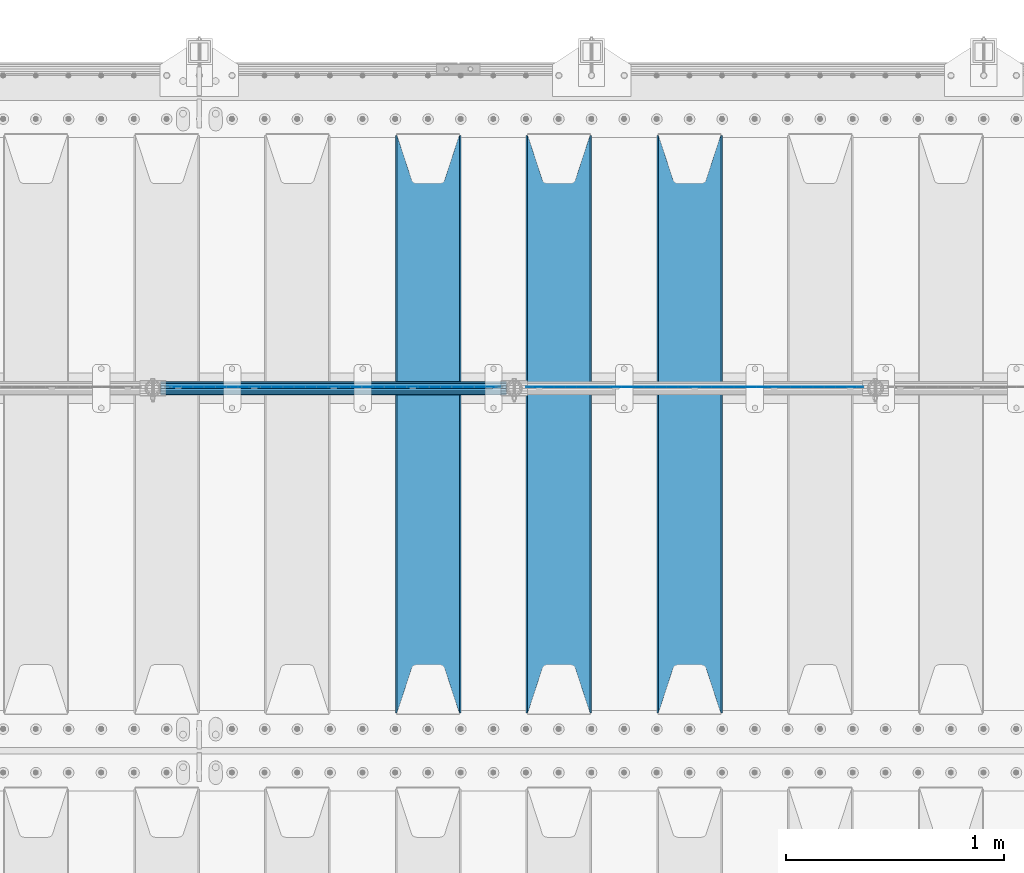
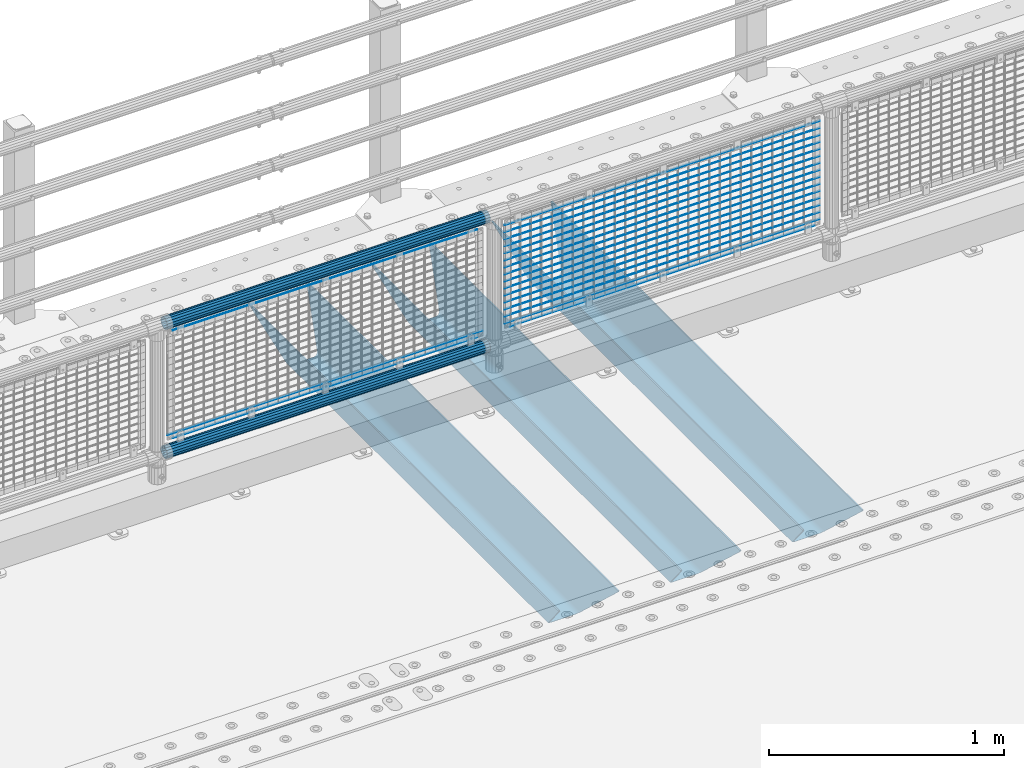
# One storey, part 91 of 193: 24 beams.
"""IFC2X3 building model written with IfcOpenShell, lengths in millimetres."""

import ifcopenshell
import ifcopenshell.guid

model = None  # the IFC model being written
_history = None  # IfcOwnerHistory: only IFC2X3 demands one
_inside = {}  # id of a spatial element -> (the spatial element, [elements in it])
_under = {}  # id of a project, library or spatial element -> (it, [spatial elements below it])
_declared = {}  # id of a project -> (the project, [libraries it declares])
_typed = {}  # id of a type object -> (the type object, [elements of that type])
_made_of = {}  # id of a material, layer set ... -> (it, [elements and type objects made of it])


def new_model(schema):
    """Start an empty IFC model of exactly this schema.

    Asked for "IFC4X3", IfcOpenShell would pick the latest addendum, in which some entities
    have other attributes; the version numbers below select the first issue.
    IFC2X3 requires an IfcOwnerHistory on every rooted entity: one is made here for all.
    """
    global model, _history
    if schema == "IFC4X3":
        model = ifcopenshell.file(schema_version=(4, 3, 0, 0))
    else:
        model = ifcopenshell.file(schema=schema)
    _inside.clear()
    _under.clear()
    _declared.clear()
    _typed.clear()
    _made_of.clear()
    _history = None
    if model.schema == "IFC2X3":
        org = make("IfcOrganization", Name="unknown")
        user = make(
            "IfcPersonAndOrganization",
            ThePerson=make("IfcPerson", FamilyName="unknown"),
            TheOrganization=org,
        )
        app = make(
            "IfcApplication",
            ApplicationDeveloper=org,
            Version="unknown",
            ApplicationFullName="unknown",
            ApplicationIdentifier="unknown",
        )
        _history = make(
            "IfcOwnerHistory",
            OwningUser=user,
            OwningApplication=app,
            ChangeAction="ADDED",
            CreationDate=0,
        )
    return model


def make(cls, **values):
    """One entity of the class cls with the attributes given. An attribute that is None is left unset."""
    return model.create_entity(
        cls, **{name: value for name, value in values.items() if value is not None}
    )


def rooted(cls, **values):
    """An entity with a GlobalId (a new one), such as an element, a storey or a relation."""
    return make(cls, GlobalId=ifcopenshell.guid.new(), OwnerHistory=_history, **values)


def si_unit(unit_type, name, prefix=None):
    """IfcSIUnit, for example si_unit("LENGTHUNIT", "METRE", prefix="MILLI")."""
    return make("IfcSIUnit", UnitType=unit_type, Prefix=prefix, Name=name)


def assignment(units):
    """IfcUnitAssignment: the units of a project."""
    return None if units is None else make("IfcUnitAssignment", Units=units)


def point(xyz):
    """IfcCartesianPoint."""
    return None if xyz is None else make("IfcCartesianPoint", Coordinates=xyz)


def direction(xyz):
    """IfcDirection."""
    return None if xyz is None else make("IfcDirection", DirectionRatios=xyz)


def frame(location, z_axis=None, x_axis=None):
    """IfcAxis2Placement3D, a coordinate frame: its origin and axes. An axis left out is left unset."""
    return make(
        "IfcAxis2Placement3D",
        Location=point(location),
        Axis=direction(z_axis),
        RefDirection=direction(x_axis),
    )


def origin_with_axes():
    """The frame at (0, 0, 0) with the z axis (0, 0, 1) and the x axis (1, 0, 0) written out."""
    return frame((0.0, 0.0, 0.0), z_axis=(0.0, 0.0, 1.0), x_axis=(1.0, 0.0, 0.0))


def place(relative_to, where):
    """IfcLocalPlacement: puts the frame where relative to a parent placement (None: the world)."""
    return make(
        "IfcLocalPlacement", PlacementRelTo=relative_to, RelativePlacement=where
    )


def context(
    kind, dimensions, precision=None, world=None, true_north=None, identifier=None
):
    """IfcGeometricRepresentationContext, for example the 3D "Model" context."""
    return make(
        "IfcGeometricRepresentationContext",
        ContextIdentifier=identifier,
        ContextType=kind,
        CoordinateSpaceDimension=dimensions,
        Precision=precision,
        WorldCoordinateSystem=world,
        TrueNorth=true_north,
    )


def subcontext(parent, identifier, kind, view, scale=None):
    """IfcGeometricRepresentationSubContext, for example "Body" below "Model"."""
    return make(
        "IfcGeometricRepresentationSubContext",
        ContextIdentifier=identifier,
        ContextType=kind,
        ParentContext=parent,
        TargetScale=scale,
        TargetView=view,
    )


def project(units=None, contexts=None):
    """IfcProject with its units and contexts."""
    return rooted(
        "IfcProject",
        Name="project",
        RepresentationContexts=contexts,
        UnitsInContext=assignment(units),
    )


def spatial(cls, under=None, at=None, **own):
    """A site, building, storey or space (cls), placed at a placement, below another one or the project."""
    s = rooted(cls, ObjectPlacement=at, **own)
    if under is not None:
        _under.setdefault(under.id(), (under, []))[1].append(s)
    return s


def faces_of(points, faces, orient=None, outer=None):
    """IfcFace entities. A face is a list of loops; a loop is a list of indices into points, from 0.

    orient and outer hold one flag for each loop. By default every Orientation is true, the
    first loop of a face is its IfcFaceOuterBound and the others are IfcFaceBound.
    """
    made = []
    for i, loops in enumerate(faces):
        bounds = []
        for j, loop in enumerate(loops):
            is_outer = j == 0 if outer is None else outer[i][j]
            bounds.append(
                make(
                    "IfcFaceOuterBound" if is_outer else "IfcFaceBound",
                    Bound=make("IfcPolyLoop", Polygon=[points[k] for k in loop]),
                    Orientation=True if orient is None else orient[i][j],
                )
            )
        made.append(make("IfcFace", Bounds=bounds))
    return made


def faceted_brep(points, faces, orient=None, outer=None, voids=None):
    """IfcFacetedBrep: a solid bounded by flat faces; with voids (closed shells), ...WithVoids."""
    shared = [point(p) for p in points]
    hull = make("IfcClosedShell", CfsFaces=faces_of(shared, faces, orient, outer))
    if voids is None:
        return make("IfcFacetedBrep", Outer=hull)
    return make(
        "IfcFacetedBrepWithVoids",
        Outer=hull,
        Voids=[
            make(cls, CfsFaces=faces_of(shared, fs, o, b)) for cls, fs, o, b in voids
        ],
    )


def shape(context_of_items, identifier, shape_type, items):
    """IfcShapeRepresentation: the items that make up one representation, for example the "Body"."""
    return make(
        "IfcShapeRepresentation",
        ContextOfItems=context_of_items,
        RepresentationIdentifier=identifier,
        RepresentationType=shape_type,
        Items=items,
    )


def material(Name=None, Category=None):
    """IfcMaterial."""
    return make("IfcMaterial", Name=Name, Category=Category)


def made_of(thing, what):
    """Note that an element or type object is made of a material, layer set ...; save() writes the relation."""
    if what is not None:
        _made_of.setdefault(what.id(), (what, []))[1].append(thing)
    return thing


def type_object(cls, material=None, **own):
    """A type object (cls), such as IfcWallType, which elements share."""
    return made_of(rooted(cls, **own), material)


def element(
    cls,
    number,
    at=None,
    inside=None,
    cuts=None,
    type_object=None,
    material=None,
    context=None,
    identifier="Body",
    shape_type=None,
    held_by="IfcProductDefinitionShape",
    body=None,
    shapes=None,
    **own,
):
    """One element of the class cls, such as IfcWall. Its Tag is "e" and its number.

    at: its placement. inside: the storey or other place that contains it. cuts: it is an
    opening in that element (IfcRelVoidsElement). A single representation is given by context,
    identifier, shape_type and body (its items); several are given by shapes. held_by: the class
    of the entity that holds the representations. save() writes the other relations.
    """
    e = rooted(cls, Tag="e%d" % number, ObjectPlacement=at, **own)
    if body is not None:
        shapes = [shape(context, identifier, shape_type, body)]
    if shapes is not None:
        e.Representation = make(held_by, Representations=shapes)
    if inside is not None:
        _inside.setdefault(inside.id(), (inside, []))[1].append(e)
    if cuts is not None:
        rooted(
            "IfcRelVoidsElement", RelatingBuildingElement=cuts, RelatedOpeningElement=e
        )
    if type_object is not None:
        _typed.setdefault(type_object.id(), (type_object, []))[1].append(e)
    return made_of(e, material)


def aggregate(whole, parts):
    """IfcRelAggregates: a whole, such as a stair, and the parts it consists of."""
    return rooted("IfcRelAggregates", RelatingObject=whole, RelatedObjects=parts)


def save(model, path):
    """Write the relations noted so far, then the file.

    IfcRelAggregates (storeys below a building ...), IfcRelContainedInSpatialStructure (elements
    in a storey), IfcRelDefinesByType, IfcRelAssociatesMaterial and IfcRelDeclares: one each for
    every whole, place, type object, material and project.
    """
    for whole, parts in _under.values():
        aggregate(whole, parts)
    for where, things in _inside.values():
        rooted(
            "IfcRelContainedInSpatialStructure",
            RelatedElements=things,
            RelatingStructure=where,
        )
    for kind, things in _typed.values():
        rooted("IfcRelDefinesByType", RelatedObjects=things, RelatingType=kind)
    for what, things in _made_of.values():
        rooted("IfcRelAssociatesMaterial", RelatedObjects=things, RelatingMaterial=what)
    for by, libraries in _declared.values():
        rooted("IfcRelDeclares", RelatingContext=by, RelatedDefinitions=libraries)
    model.write(path)


model = new_model("IFC2X3")

# Units and contexts
model_context = context("Model", 3, precision=1e-05, world=origin_with_axes())
body_context = subcontext(model_context, "Body", "Model", "MODEL_VIEW")
ifc_project = project(units=[si_unit("LENGTHUNIT", "METRE", prefix="MILLI"), si_unit("AREAUNIT", "SQUARE_METRE"), si_unit("VOLUMEUNIT", "CUBIC_METRE"), si_unit("MASSUNIT", "GRAM", prefix="KILO"), si_unit("TIMEUNIT", "SECOND"), si_unit("PLANEANGLEUNIT", "RADIAN"), si_unit("SOLIDANGLEUNIT", "STERADIAN"), si_unit("THERMODYNAMICTEMPERATUREUNIT", "DEGREE_CELSIUS"), si_unit("LUMINOUSINTENSITYUNIT", "LUMEN")], contexts=[model_context])

# Site, building, storey
site_placement = place(None, origin_with_axes())
site = spatial("IfcSite", under=ifc_project, at=site_placement, CompositionType="ELEMENT")
building_placement = place(site_placement, origin_with_axes())
building = spatial("IfcBuilding", under=site, at=building_placement, Name="Standard", CompositionType="ELEMENT")
storey_placement = place(building_placement, origin_with_axes())
storey = spatial("IfcBuildingStorey", under=building, at=storey_placement, Name="Undefined", CompositionType="ELEMENT", Elevation=0.0)

# Beams
ifc_material_1 = material(Name="STEEL/S355N")
beam_type_1 = type_object("IfcBeamType", PredefinedType="NOTDEFINED")
beam_1_placement = place(storey_placement, frame((-36050.0, 27175.0, -115.0), z_axis=(0.0, 0.0, 1.0), x_axis=(0.0, 1.0, 0.0)))
element("IfcBeam", 1, at=beam_1_placement, inside=storey, type_object=beam_type_1, material=ifc_material_1, context=body_context, shape_type="Brep", body=[
    faceted_brep([(0.0, 150.0, 115.0), (0.0, 143.689999999999, 115.0), (2650.00000000297, 143.689999999999, 115.0), (2650.00000000297, 150.0, 115.0), (2650.00000000297, 142.059565218398, 110.000000003094), (2650.00000000297, 148.3695652184, 110.000000003094), (2441.90079219209, -80.1103600731112, -98.0992078077845), (2437.7588105432, -77.5672621345584, -102.241189456673), (2434.06523489747, -74.4080125315522, -105.934765102404), (2430.9108609509, -70.710272125576, -109.089139048974), (2428.37322971128, -66.5649389910068, -111.626770288588), (2426.51472138055, -62.0739139532889, -113.485278619323), (2425.38102192092, -57.3475956567672, -114.618978078955), (2424.99999999988, -52.5021667386536, -115.0), (2424.99999999988, 52.5021667386536, -115.0), (2425.38102192092, 57.3475956567672, -114.618978078955), (2426.51472138055, 62.0739139532889, -113.485278619323), (2428.37322971128, 66.5649389910068, -111.626770288588), (2430.9108609509, 70.710272125576, -109.089139048974), (2434.06523489747, 74.4080125315522, -105.934765102404), (2437.7588105432, 77.5672621345584, -102.241189456673), (2441.90079219209, 80.1103600731112, -98.0992078077846), (2446.38936140512, 81.9747917625791, -93.6106385947584), (2448.2494850041, 76.2713538057251, -91.7505149957729), (2444.62967112263, 74.76777986261, -95.3703288772456), (2441.28936334127, 72.7168944282894, -98.710636658607), (2438.31067330439, 70.1691124903846, -101.689326695487), (2435.76682334748, 67.1870637758839, -104.233176652398), (2433.72034654134, 63.8440531834895, -106.279653458539), (2432.22154950042, 60.222258798236, -107.778450499454), (2431.30727574265, 56.4107117849089, -108.692724257221), (2430.99999999987, 52.5031078186876, -109.0), (2430.99999999987, -52.5031078186876, -109.0), (2431.30727574265, -56.4107117849089, -108.692724257221), (2432.22154950042, -60.222258798236, -107.778450499454), (2433.72034654134, -63.8440531834895, -106.279653458539), (2435.76682334748, -67.1870637758839, -104.233176652398), (2438.31067330439, -70.1691124903846, -101.689326695487), (2441.28936334127, -72.7168944282894, -98.7106366586071), (2444.62967112263, -74.76777986261, -95.3703288772457), (2448.2494850041, -76.2713538057251, -91.7505149957729), (2650.00000000297, -142.059565218398, 110.000000003094), (2650.00000000297, -148.3695652184, 110.000000003094), (2446.38936140512, -81.9747917625791, -93.6106385947584), (2650.00000000297, -143.689999999999, 115.0), (2650.00000000297, -150.0, 115.0), (0.0, -143.689999999999, 115.0), (0.0, -150.0, 115.0), (0.0, -148.369565218261, 110.000000002667), (203.610638597427, -81.9747917625791, -93.6106385947584), (208.099207810446, -80.1103600731112, -98.0992078077845), (212.241189459342, -77.5672621345584, -102.241189456673), (215.93476510507, -74.4080125315522, -105.934765102404), (219.089139051641, -70.710272125576, -109.089139048974), (221.626770291256, -66.5649389910068, -111.626770288588), (223.485278621989, -62.0739139532889, -113.485278619323), (224.618978081624, -57.3475956567672, -114.618978078955), (225.000000002663, -52.5021667386536, -115.0), (225.000000002663, 52.5021667386536, -115.0), (224.618978081624, 57.3475956567672, -114.618978078955), (223.485278621989, 62.0739139532889, -113.485278619323), (221.626770291256, 66.5649389910068, -111.626770288588), (219.089139051641, 70.710272125576, -109.089139048974), (215.93476510507, 74.4080125315522, -105.934765102404), (212.241189459342, 77.5672621345584, -102.241189456673), (208.099207810446, 80.1103600731112, -98.0992078077846), (203.610638597427, 81.9747917625791, -93.6106385947584), (0.0, 148.369565218261, 110.000000002667), (0.0, 142.05956521826, 110.000000002667), (201.750514998439, 76.2713538057251, -91.7505149957729), (205.370328879915, 74.76777986261, -95.3703288772456), (208.710636661275, 72.7168944282894, -98.710636658607), (211.689326698157, 70.1691124903846, -101.689326695487), (214.233176655063, 67.1870637758839, -104.233176652398), (216.279653461206, 63.8440531834895, -106.279653458539), (217.778450502123, 60.222258798236, -107.778450499454), (218.69272425989, 56.4107117849089, -108.692724257221), (219.00000000267, 52.5031078186876, -109.0), (219.00000000267, -52.5031078186876, -109.0), (218.69272425989, -56.4107117849089, -108.692724257221), (217.778450502123, -60.222258798236, -107.778450499454), (216.279653461206, -63.8440531834895, -106.279653458539), (214.233176655063, -67.1870637758839, -104.233176652398), (211.689326698157, -70.1691124903846, -101.689326695487), (208.710636661275, -72.7168944282894, -98.7106366586071), (205.370328879915, -74.76777986261, -95.3703288772457), (201.750514998439, -76.2713538057251, -91.7505149957729), (0.0, -142.05956521826, 110.000000002667)], [[[0, 1, 2, 3]], [[3, 2, 4, 5]], [[6, 7, 8, 9, 10, 11, 12, 13, 14, 15, 16, 17, 18, 19, 20, 21, 22, 5, 4, 23, 24, 25, 26, 27, 28, 29, 30, 31, 32, 33, 34, 35, 36, 37, 38, 39, 40, 41, 42, 43]], [[44, 45, 42, 41]], [[46, 47, 45, 44]], [[43, 42, 45, 47, 48, 49]], [[6, 43, 49, 50]], [[7, 6, 50, 51]], [[8, 7, 51, 52]], [[9, 8, 52, 53]], [[10, 9, 53, 54]], [[11, 10, 54, 55]], [[12, 11, 55, 56]], [[13, 12, 56, 57]], [[14, 13, 57, 58]], [[15, 14, 58, 59]], [[16, 15, 59, 60]], [[17, 16, 60, 61]], [[18, 17, 61, 62]], [[19, 18, 62, 63]], [[20, 19, 63, 64]], [[21, 20, 64, 65]], [[22, 21, 65, 66]], [[0, 3, 5, 22, 66, 67]], [[1, 0, 67, 68]], [[23, 4, 2, 1, 68, 69]], [[24, 23, 69, 70]], [[25, 24, 70, 71]], [[26, 25, 71, 72]], [[27, 26, 72, 73]], [[28, 27, 73, 74]], [[29, 28, 74, 75]], [[30, 29, 75, 76]], [[31, 30, 76, 77]], [[32, 31, 77, 78]], [[33, 32, 78, 79]], [[34, 33, 79, 80]], [[35, 34, 80, 81]], [[36, 35, 81, 82]], [[37, 36, 82, 83]], [[38, 37, 83, 84]], [[39, 38, 84, 85]], [[40, 39, 85, 86]], [[46, 44, 41, 40, 86, 87]], [[47, 46, 87, 48]], [[86, 85, 84, 83, 82, 81, 80, 79, 78, 77, 76, 75, 74, 73, 72, 71, 70, 69, 68, 67, 66, 65, 64, 63, 62, 61, 60, 59, 58, 57, 56, 55, 54, 53, 52, 51, 50, 49, 48, 87]]]),
])
beam_2_placement = place(storey_placement, frame((-36650.0, 27175.0, -115.0), z_axis=(0.0, 0.0, 1.0), x_axis=(0.0, 1.0, 0.0)))
element("IfcBeam", 2, at=beam_2_placement, inside=storey, type_object=beam_type_1, material=ifc_material_1, context=body_context, shape_type="Brep", body=[
    faceted_brep([(0.0, 150.0, 115.0), (0.0, 143.689999999999, 115.0), (2650.00000000297, 143.689999999999, 115.0), (2650.00000000297, 150.0, 115.0), (2650.00000000297, 142.059565218398, 110.000000003094), (2650.00000000297, 148.3695652184, 110.000000003094), (2441.90079219209, -80.1103600731112, -98.0992078077845), (2437.7588105432, -77.5672621345584, -102.241189456673), (2434.06523489747, -74.4080125315522, -105.934765102404), (2430.9108609509, -70.710272125576, -109.089139048974), (2428.37322971128, -66.5649389910068, -111.626770288588), (2426.51472138055, -62.0739139532889, -113.485278619323), (2425.38102192092, -57.3475956567672, -114.618978078955), (2424.99999999988, -52.5021667386536, -115.0), (2424.99999999988, 52.5021667386536, -115.0), (2425.38102192092, 57.3475956567672, -114.618978078955), (2426.51472138055, 62.0739139532889, -113.485278619323), (2428.37322971128, 66.5649389910068, -111.626770288588), (2430.9108609509, 70.710272125576, -109.089139048974), (2434.06523489747, 74.4080125315522, -105.934765102404), (2437.7588105432, 77.5672621345584, -102.241189456673), (2441.90079219209, 80.1103600731112, -98.0992078077846), (2446.38936140512, 81.9747917625791, -93.6106385947584), (2448.2494850041, 76.2713538057251, -91.7505149957729), (2444.62967112263, 74.76777986261, -95.3703288772456), (2441.28936334127, 72.7168944282894, -98.710636658607), (2438.31067330439, 70.1691124903846, -101.689326695487), (2435.76682334748, 67.1870637758839, -104.233176652398), (2433.72034654134, 63.8440531834895, -106.279653458539), (2432.22154950042, 60.222258798236, -107.778450499454), (2431.30727574265, 56.4107117849089, -108.692724257221), (2430.99999999987, 52.5031078186876, -109.0), (2430.99999999987, -52.5031078186876, -109.0), (2431.30727574265, -56.4107117849089, -108.692724257221), (2432.22154950042, -60.222258798236, -107.778450499454), (2433.72034654134, -63.8440531834895, -106.279653458539), (2435.76682334748, -67.1870637758839, -104.233176652398), (2438.31067330439, -70.1691124903846, -101.689326695487), (2441.28936334127, -72.7168944282894, -98.7106366586071), (2444.62967112263, -74.76777986261, -95.3703288772457), (2448.2494850041, -76.2713538057251, -91.7505149957729), (2650.00000000297, -142.059565218398, 110.000000003094), (2650.00000000297, -148.3695652184, 110.000000003094), (2446.38936140512, -81.9747917625791, -93.6106385947584), (2650.00000000297, -143.689999999999, 115.0), (2650.00000000297, -150.0, 115.0), (0.0, -143.689999999999, 115.0), (0.0, -150.0, 115.0), (0.0, -148.369565218261, 110.000000002667), (203.610638597427, -81.9747917625791, -93.6106385947584), (208.099207810446, -80.1103600731112, -98.0992078077845), (212.241189459342, -77.5672621345584, -102.241189456673), (215.93476510507, -74.4080125315522, -105.934765102404), (219.089139051641, -70.710272125576, -109.089139048974), (221.626770291256, -66.5649389910068, -111.626770288588), (223.485278621989, -62.0739139532889, -113.485278619323), (224.618978081624, -57.3475956567672, -114.618978078955), (225.000000002663, -52.5021667386536, -115.0), (225.000000002663, 52.5021667386536, -115.0), (224.618978081624, 57.3475956567672, -114.618978078955), (223.485278621989, 62.0739139532889, -113.485278619323), (221.626770291256, 66.5649389910068, -111.626770288588), (219.089139051641, 70.710272125576, -109.089139048974), (215.93476510507, 74.4080125315522, -105.934765102404), (212.241189459342, 77.5672621345584, -102.241189456673), (208.099207810446, 80.1103600731112, -98.0992078077846), (203.610638597427, 81.9747917625791, -93.6106385947584), (0.0, 148.369565218261, 110.000000002667), (0.0, 142.05956521826, 110.000000002667), (201.750514998439, 76.2713538057251, -91.7505149957729), (205.370328879915, 74.76777986261, -95.3703288772456), (208.710636661275, 72.7168944282894, -98.710636658607), (211.689326698157, 70.1691124903846, -101.689326695487), (214.233176655063, 67.1870637758839, -104.233176652398), (216.279653461206, 63.8440531834895, -106.279653458539), (217.778450502123, 60.222258798236, -107.778450499454), (218.69272425989, 56.4107117849089, -108.692724257221), (219.00000000267, 52.5031078186876, -109.0), (219.00000000267, -52.5031078186876, -109.0), (218.69272425989, -56.4107117849089, -108.692724257221), (217.778450502123, -60.222258798236, -107.778450499454), (216.279653461206, -63.8440531834895, -106.279653458539), (214.233176655063, -67.1870637758839, -104.233176652398), (211.689326698157, -70.1691124903846, -101.689326695487), (208.710636661275, -72.7168944282894, -98.7106366586071), (205.370328879915, -74.76777986261, -95.3703288772457), (201.750514998439, -76.2713538057251, -91.7505149957729), (0.0, -142.05956521826, 110.000000002667)], [[[0, 1, 2, 3]], [[3, 2, 4, 5]], [[6, 7, 8, 9, 10, 11, 12, 13, 14, 15, 16, 17, 18, 19, 20, 21, 22, 5, 4, 23, 24, 25, 26, 27, 28, 29, 30, 31, 32, 33, 34, 35, 36, 37, 38, 39, 40, 41, 42, 43]], [[44, 45, 42, 41]], [[46, 47, 45, 44]], [[43, 42, 45, 47, 48, 49]], [[6, 43, 49, 50]], [[7, 6, 50, 51]], [[8, 7, 51, 52]], [[9, 8, 52, 53]], [[10, 9, 53, 54]], [[11, 10, 54, 55]], [[12, 11, 55, 56]], [[13, 12, 56, 57]], [[14, 13, 57, 58]], [[15, 14, 58, 59]], [[16, 15, 59, 60]], [[17, 16, 60, 61]], [[18, 17, 61, 62]], [[19, 18, 62, 63]], [[20, 19, 63, 64]], [[21, 20, 64, 65]], [[22, 21, 65, 66]], [[0, 3, 5, 22, 66, 67]], [[1, 0, 67, 68]], [[23, 4, 2, 1, 68, 69]], [[24, 23, 69, 70]], [[25, 24, 70, 71]], [[26, 25, 71, 72]], [[27, 26, 72, 73]], [[28, 27, 73, 74]], [[29, 28, 74, 75]], [[30, 29, 75, 76]], [[31, 30, 76, 77]], [[32, 31, 77, 78]], [[33, 32, 78, 79]], [[34, 33, 79, 80]], [[35, 34, 80, 81]], [[36, 35, 81, 82]], [[37, 36, 82, 83]], [[38, 37, 83, 84]], [[39, 38, 84, 85]], [[40, 39, 85, 86]], [[46, 44, 41, 40, 86, 87]], [[47, 46, 87, 48]], [[86, 85, 84, 83, 82, 81, 80, 79, 78, 77, 76, 75, 74, 73, 72, 71, 70, 69, 68, 67, 66, 65, 64, 63, 62, 61, 60, 59, 58, 57, 56, 55, 54, 53, 52, 51, 50, 49, 48, 87]]]),
])
beam_3_placement = place(storey_placement, frame((-37250.0, 27175.0, -115.0), z_axis=(0.0, 0.0, 1.0), x_axis=(0.0, 1.0, 0.0)))
element("IfcBeam", 3, at=beam_3_placement, inside=storey, type_object=beam_type_1, material=ifc_material_1, context=body_context, shape_type="Brep", body=[
    faceted_brep([(0.0, 150.0, 115.0), (0.0, 143.689999999999, 115.0), (2650.00000000297, 143.689999999999, 115.0), (2650.00000000297, 150.0, 115.0), (2650.00000000297, 142.059565218398, 110.000000003094), (2650.00000000297, 148.3695652184, 110.000000003094), (2441.90079219209, -80.1103600731112, -98.0992078077845), (2437.7588105432, -77.5672621345584, -102.241189456673), (2434.06523489747, -74.4080125315522, -105.934765102404), (2430.9108609509, -70.710272125576, -109.089139048974), (2428.37322971128, -66.5649389910068, -111.626770288588), (2426.51472138055, -62.0739139532889, -113.485278619323), (2425.38102192092, -57.3475956567672, -114.618978078955), (2424.99999999988, -52.5021667386536, -115.0), (2424.99999999988, 52.5021667386536, -115.0), (2425.38102192092, 57.3475956567672, -114.618978078955), (2426.51472138055, 62.0739139532889, -113.485278619323), (2428.37322971128, 66.5649389910068, -111.626770288588), (2430.9108609509, 70.710272125576, -109.089139048974), (2434.06523489747, 74.4080125315522, -105.934765102404), (2437.7588105432, 77.5672621345584, -102.241189456673), (2441.90079219209, 80.1103600731112, -98.0992078077846), (2446.38936140512, 81.9747917625791, -93.6106385947584), (2448.2494850041, 76.2713538057251, -91.7505149957729), (2444.62967112263, 74.76777986261, -95.3703288772456), (2441.28936334127, 72.7168944282894, -98.710636658607), (2438.31067330439, 70.1691124903846, -101.689326695487), (2435.76682334748, 67.1870637758839, -104.233176652398), (2433.72034654134, 63.8440531834895, -106.279653458539), (2432.22154950042, 60.222258798236, -107.778450499454), (2431.30727574265, 56.4107117849089, -108.692724257221), (2430.99999999987, 52.5031078186876, -109.0), (2430.99999999987, -52.5031078186876, -109.0), (2431.30727574265, -56.4107117849089, -108.692724257221), (2432.22154950042, -60.222258798236, -107.778450499454), (2433.72034654134, -63.8440531834895, -106.279653458539), (2435.76682334748, -67.1870637758839, -104.233176652398), (2438.31067330439, -70.1691124903846, -101.689326695487), (2441.28936334127, -72.7168944282894, -98.7106366586071), (2444.62967112263, -74.76777986261, -95.3703288772457), (2448.2494850041, -76.2713538057251, -91.7505149957729), (2650.00000000297, -142.059565218398, 110.000000003094), (2650.00000000297, -148.3695652184, 110.000000003094), (2446.38936140512, -81.9747917625791, -93.6106385947584), (2650.00000000297, -143.689999999999, 115.0), (2650.00000000297, -150.0, 115.0), (0.0, -143.689999999999, 115.0), (0.0, -150.0, 115.0), (0.0, -148.369565218261, 110.000000002667), (203.610638597427, -81.9747917625791, -93.6106385947584), (208.099207810446, -80.1103600731112, -98.0992078077845), (212.241189459342, -77.5672621345584, -102.241189456673), (215.93476510507, -74.4080125315522, -105.934765102404), (219.089139051641, -70.710272125576, -109.089139048974), (221.626770291256, -66.5649389910068, -111.626770288588), (223.485278621989, -62.0739139532889, -113.485278619323), (224.618978081624, -57.3475956567672, -114.618978078955), (225.000000002663, -52.5021667386536, -115.0), (225.000000002663, 52.5021667386536, -115.0), (224.618978081624, 57.3475956567672, -114.618978078955), (223.485278621989, 62.0739139532889, -113.485278619323), (221.626770291256, 66.5649389910068, -111.626770288588), (219.089139051641, 70.710272125576, -109.089139048974), (215.93476510507, 74.4080125315522, -105.934765102404), (212.241189459342, 77.5672621345584, -102.241189456673), (208.099207810446, 80.1103600731112, -98.0992078077846), (203.610638597427, 81.9747917625791, -93.6106385947584), (0.0, 148.369565218261, 110.000000002667), (0.0, 142.05956521826, 110.000000002667), (201.750514998439, 76.2713538057251, -91.7505149957729), (205.370328879915, 74.76777986261, -95.3703288772456), (208.710636661275, 72.7168944282894, -98.710636658607), (211.689326698157, 70.1691124903846, -101.689326695487), (214.233176655063, 67.1870637758839, -104.233176652398), (216.279653461206, 63.8440531834895, -106.279653458539), (217.778450502123, 60.222258798236, -107.778450499454), (218.69272425989, 56.4107117849089, -108.692724257221), (219.00000000267, 52.5031078186876, -109.0), (219.00000000267, -52.5031078186876, -109.0), (218.69272425989, -56.4107117849089, -108.692724257221), (217.778450502123, -60.222258798236, -107.778450499454), (216.279653461206, -63.8440531834895, -106.279653458539), (214.233176655063, -67.1870637758839, -104.233176652398), (211.689326698157, -70.1691124903846, -101.689326695487), (208.710636661275, -72.7168944282894, -98.7106366586071), (205.370328879915, -74.76777986261, -95.3703288772457), (201.750514998439, -76.2713538057251, -91.7505149957729), (0.0, -142.05956521826, 110.000000002667)], [[[0, 1, 2, 3]], [[3, 2, 4, 5]], [[6, 7, 8, 9, 10, 11, 12, 13, 14, 15, 16, 17, 18, 19, 20, 21, 22, 5, 4, 23, 24, 25, 26, 27, 28, 29, 30, 31, 32, 33, 34, 35, 36, 37, 38, 39, 40, 41, 42, 43]], [[44, 45, 42, 41]], [[46, 47, 45, 44]], [[43, 42, 45, 47, 48, 49]], [[6, 43, 49, 50]], [[7, 6, 50, 51]], [[8, 7, 51, 52]], [[9, 8, 52, 53]], [[10, 9, 53, 54]], [[11, 10, 54, 55]], [[12, 11, 55, 56]], [[13, 12, 56, 57]], [[14, 13, 57, 58]], [[15, 14, 58, 59]], [[16, 15, 59, 60]], [[17, 16, 60, 61]], [[18, 17, 61, 62]], [[19, 18, 62, 63]], [[20, 19, 63, 64]], [[21, 20, 64, 65]], [[22, 21, 65, 66]], [[0, 3, 5, 22, 66, 67]], [[1, 0, 67, 68]], [[23, 4, 2, 1, 68, 69]], [[24, 23, 69, 70]], [[25, 24, 70, 71]], [[26, 25, 71, 72]], [[27, 26, 72, 73]], [[28, 27, 73, 74]], [[29, 28, 74, 75]], [[30, 29, 75, 76]], [[31, 30, 76, 77]], [[32, 31, 77, 78]], [[33, 32, 78, 79]], [[34, 33, 79, 80]], [[35, 34, 80, 81]], [[36, 35, 81, 82]], [[37, 36, 82, 83]], [[38, 37, 83, 84]], [[39, 38, 84, 85]], [[40, 39, 85, 86]], [[46, 44, 41, 40, 86, 87]], [[47, 46, 87, 48]], [[86, 85, 84, 83, 82, 81, 80, 79, 78, 77, 76, 75, 74, 73, 72, 71, 70, 69, 68, 67, 66, 65, 64, 63, 62, 61, 60, 59, 58, 57, 56, 55, 54, 53, 52, 51, 50, 49, 48, 87]]]),
])
ifc_material_2 = material(Name="Misc_Undefined")
beam_type_2 = type_object("IfcBeamType", Name="D3", PredefinedType="NOTDEFINED")
for number, where, z_axis, x_axis in (
    (4, (-36800.0, 28670.5, 851.597), (0.0, 0.0, 1.0), (1.0, 0.0, 0.0)),
    (5, (-36800.0, 28670.5, 669.452), (0.0, 0.0, 1.0), (1.0, 0.0, 0.0)),
    (6, (-36800.0, 28670.5, 523.736), (0.0, 0.0, 1.0), (1.0, 0.0, 0.0)),
    (7, (-36800.0, 28670.5, 487.307), (0.0, 0.0, 1.0), (1.0, 0.0, 0.0)),
    (8, (-36800.0, 28670.5, 705.881), (0.0, 0.0, 1.0), (1.0, 0.0, 0.0)),
    (9, (-36800.0, 28670.5, 596.594000000001), (0.0, 0.0, 1.0), (1.0, 0.0, 0.0)),
    (10, (-36800.0, 28670.5, 450.878), (0.0, 0.0, 1.0), (1.0, 0.0, 0.0)),
    (11, (-36800.0, 28670.5, 815.168), (0.0, 0.0, 1.0), (1.0, 0.0, 0.0)),
    (12, (-36800.0, 28670.5, 888.026), (0.0, 0.0, 1.0), (1.0, 0.0, 0.0)),
    (13, (-36800.0, 28670.5, 778.739), (0.0, 0.0, 1.0), (1.0, 0.0, 0.0)),
    (14, (-36800.0, 28670.5, 742.31), (0.0, 0.0, 1.0), (1.0, 0.0, 0.0)),
    (15, (-36800.0, 28670.5, 633.023), (0.0, 0.0, 1.0), (1.0, 0.0, 0.0)),
    (16, (-36800.0, 28670.5, 560.165), (0.0, 0.0, 1.0), (1.0, 0.0, 0.0)),
    (17, (-36800.0, 28670.5, 414.449), (0.0, 0.0, 1.0), (1.0, 0.0, 0.0)),
):
    element("IfcBeam", number, at=place(storey_placement, frame(where, z_axis=z_axis, x_axis=x_axis)), inside=storey, type_object=beam_type_2, material=ifc_material_2, ObjectType="D3", context=body_context, shape_type="Brep", body=[
        faceted_brep([(0.0, -1.49999999999636, 3.63797880709171e-12), (0.0, -0.75, -1.29903810567669), (1548.0, -0.75, -1.29903810567669), (1548.0, -1.5, 0.0), (0.0, 0.75, -1.29903810567669), (1548.0, 0.75, -1.29903810567669), (0.0, 1.50000000000364, 7.27595761418343e-12), (1548.0, 1.5, 0.0), (0.0, 0.75, 1.29903810567669), (1548.0, 0.75, 1.29903810567669), (0.0, -0.75, 1.29903810567669), (1548.0, -0.75, 1.29903810567669)], [[[0, 1, 2, 3]], [[1, 4, 5, 2]], [[4, 6, 7, 5]], [[6, 8, 9, 7]], [[8, 10, 11, 9]], [[10, 0, 3, 11]], [[5, 7, 9, 11, 3, 2]], [[10, 8, 6, 4, 1, 0]]]),
    ])
beam_4_placement = place(storey_placement, frame((-36775.0, 28670.5, 353.02), z_axis=(0.0, 0.0, 1.0), x_axis=(1.0, 0.0, 0.0)))
element("IfcBeam", 18, at=beam_4_placement, inside=storey, type_object=beam_type_2, material=ifc_material_2, ObjectType="D3", context=body_context, shape_type="Brep", body=[
    faceted_brep([(0.0, -1.49999999999636, 3.63797880709171e-12), (0.0, -0.75, -1.29903810567669), (1498.0, -0.75, -1.29903810567669), (1498.0, -1.5, 0.0), (0.0, 0.75, -1.29903810567669), (1498.0, 0.75, -1.29903810567663), (0.0, 1.50000000000364, 7.27595761418343e-12), (1498.0, 1.5, 0.0), (0.0, 0.75, 1.29903810567669), (1498.0, 0.75, 1.29903810567669), (0.0, -0.75, 1.29903810567669), (1498.0, -0.75, 1.29903810567669)], [[[0, 1, 2, 3]], [[1, 4, 5, 2]], [[4, 6, 7, 5]], [[6, 8, 9, 7]], [[8, 10, 11, 9]], [[10, 0, 3, 11]], [[5, 7, 9, 11, 3, 2]], [[10, 8, 6, 4, 1, 0]]]),
])
beam_5_placement = place(storey_placement, frame((-36800.0, 28670.5, 378.02), z_axis=(0.0, 0.0, 1.0), x_axis=(1.0, 0.0, 0.0)))
element("IfcBeam", 19, at=beam_5_placement, inside=storey, type_object=beam_type_2, material=ifc_material_2, ObjectType="D3", context=body_context, shape_type="Brep", body=[
    faceted_brep([(0.0, -1.49999999999636, 3.63797880709171e-12), (0.0, -0.75, -1.29903810567669), (1548.0, -0.75, -1.29903810567669), (1548.0, -1.5, 0.0), (0.0, 0.75, -1.29903810567669), (1548.0, 0.75, -1.29903810567669), (0.0, 1.50000000000364, 7.27595761418343e-12), (1548.0, 1.5, 0.0), (0.0, 0.75, 1.29903810567669), (1548.0, 0.75, 1.29903810567669), (0.0, -0.75, 1.29903810567669), (1548.0, -0.75, 1.29903810567669)], [[[0, 1, 2, 3]], [[1, 4, 5, 2]], [[4, 6, 7, 5]], [[6, 8, 9, 7]], [[8, 10, 11, 9]], [[10, 0, 3, 11]], [[5, 7, 9, 11, 3, 2]], [[10, 8, 6, 4, 1, 0]]]),
])
beam_6_placement = place(storey_placement, frame((-38433.0, 28670.5, 353.02), z_axis=(0.0, 0.0, 1.0), x_axis=(1.0, 0.0, 0.0)))
element("IfcBeam", 20, at=beam_6_placement, inside=storey, type_object=beam_type_2, material=ifc_material_2, ObjectType="D3", context=body_context, shape_type="Brep", body=[
    faceted_brep([(0.0, -1.49999999999636, 3.63797880709171e-12), (0.0, -0.75, -1.29903810567669), (1498.0, -0.75, -1.29903810567669), (1498.0, -1.5, 0.0), (0.0, 0.75, -1.29903810567669), (1498.0, 0.75, -1.29903810567663), (0.0, 1.50000000000364, 7.27595761418343e-12), (1498.0, 1.5, 0.0), (0.0, 0.75, 1.29903810567669), (1498.0, 0.75, 1.29903810567669), (0.0, -0.75, 1.29903810567669), (1498.0, -0.75, 1.29903810567669)], [[[0, 1, 2, 3]], [[1, 4, 5, 2]], [[4, 6, 7, 5]], [[6, 8, 9, 7]], [[8, 10, 11, 9]], [[10, 0, 3, 11]], [[5, 7, 9, 11, 3, 2]], [[10, 8, 6, 4, 1, 0]]]),
])
beam_7_placement = place(storey_placement, frame((-38458.0, 28670.5, 378.02), z_axis=(0.0, 0.0, 1.0), x_axis=(1.0, 0.0, 0.0)))
element("IfcBeam", 21, at=beam_7_placement, inside=storey, type_object=beam_type_2, material=ifc_material_2, ObjectType="D3", context=body_context, shape_type="Brep", body=[
    faceted_brep([(0.0, -1.49999999999636, 3.63797880709171e-12), (0.0, -0.75, -1.29903810567669), (1548.0, -0.75, -1.29903810567669), (1548.0, -1.5, 0.0), (0.0, 0.75, -1.29903810567669), (1548.0, 0.75, -1.29903810567669), (0.0, 1.50000000000364, 7.27595761418343e-12), (1548.0, 1.5, 0.0), (0.0, 0.75, 1.29903810567669), (1548.0, 0.75, 1.29903810567669), (0.0, -0.75, 1.29903810567669), (1548.0, -0.75, 1.29903810567669)], [[[0, 1, 2, 3]], [[1, 4, 5, 2]], [[4, 6, 7, 5]], [[6, 8, 9, 7]], [[8, 10, 11, 9]], [[10, 0, 3, 11]], [[5, 7, 9, 11, 3, 2]], [[10, 8, 6, 4, 1, 0]]]),
])
beam_8_placement = place(storey_placement, frame((-38433.0, 28670.5, 913.02), z_axis=(0.0, 0.0, 1.0), x_axis=(1.0, 0.0, 0.0)))
element("IfcBeam", 22, at=beam_8_placement, inside=storey, type_object=beam_type_2, material=ifc_material_2, ObjectType="D3", context=body_context, shape_type="Brep", body=[
    faceted_brep([(0.0, -1.49999999999636, 3.63797880709171e-12), (0.0, -0.75, -1.29903810567669), (1498.0, -0.75, -1.29903810567669), (1498.0, -1.5, 0.0), (0.0, 0.75, -1.29903810567669), (1498.0, 0.75, -1.29903810567663), (0.0, 1.50000000000364, 7.27595761418343e-12), (1498.0, 1.5, 0.0), (0.0, 0.75, 1.29903810567669), (1498.0, 0.75, 1.29903810567669), (0.0, -0.75, 1.29903810567669), (1498.0, -0.75, 1.29903810567669)], [[[0, 1, 2, 3]], [[1, 4, 5, 2]], [[4, 6, 7, 5]], [[6, 8, 9, 7]], [[8, 10, 11, 9]], [[10, 0, 3, 11]], [[5, 7, 9, 11, 3, 2]], [[10, 8, 6, 4, 1, 0]]]),
])
ifc_material_3 = material()
beam_type_3 = type_object("IfcBeamType", PredefinedType="NOTDEFINED")
beam_9_placement = place(storey_placement, frame((-38478.15, 28664.5, 969.85), z_axis=(0.0, 0.0, 1.0), x_axis=(1.0, 0.0, 0.0)))
element("IfcBeam", 23, at=beam_9_placement, inside=storey, type_object=beam_type_3, material=ifc_material_3, context=body_context, shape_type="Brep", body=[
    faceted_brep([(0.0, -25.3499999999985, 0.0), (0.0, -23.4203461491597, 9.70102501045403), (1588.0, -23.4203461491597, 9.70102501045506), (1588.0, -25.3499999999985, 0.0), (0.0, -17.9251569030785, 17.9251569030785), (1588.0, -17.9251569030785, 17.925156903079), (0.0, -9.70102501045403, 23.4203461491597), (1588.0, -9.70102501045403, 23.4203461491611), (0.0, 0.0, 25.3499999999985), (1588.0, 0.0, 25.35), (0.0, 9.70102501045403, 23.4203461491597), (1588.0, 9.70102501045403, 23.4203461491611), (0.0, 17.9251569030785, 17.9251569030785), (1588.0, 17.9251569030785, 17.925156903079), (0.0, 23.4203461491597, 9.70102501045403), (1588.0, 23.4203461491597, 9.70102501045506), (0.0, 25.3499999999985, 0.0), (1588.0, 25.3499999999985, 0.0), (0.0, 23.4203461491597, -9.70102501045403), (1588.0, 23.4203461491597, -9.70102501045506), (0.0, 17.9251569030785, -17.9251569030785), (1588.0, 17.9251569030785, -17.925156903079), (0.0, 9.70102501045403, -23.4203461491597), (1588.0, 9.70102501045403, -23.4203461491611), (0.0, 0.0, -25.3499999999985), (1588.0, 0.0, -25.35), (0.0, -9.70102501045403, -23.4203461491597), (1588.0, -9.70102501045403, -23.4203461491611), (0.0, -17.9251569030785, -17.9251569030785), (1588.0, -17.9251569030785, -17.925156903079), (0.0, -23.4203461491597, -9.70102501045403), (1588.0, -23.4203461491597, -9.70102501045506), (0.0, -30.1500000000015, 0.0), (0.0, -27.8549679052157, -11.5379054858058), (1588.0, -27.8549679052157, -11.5379054858075), (1588.0, -30.1500000000015, 0.0), (0.0, -21.3192694527752, -21.3192694527752), (1588.0, -21.3192694527752, -21.3192694527744), (0.0, -11.5379054858058, -27.8549679052157), (1588.0, -11.5379054858058, -27.8549679052153), (0.0, 0.0, -30.1500000000015), (1588.0, 0.0, -30.15), (0.0, 11.5379054858058, -27.8549679052157), (1588.0, 11.5379054858058, -27.8549679052153), (0.0, 21.3192694527752, -21.3192694527752), (1588.0, 21.3192694527752, -21.3192694527744), (0.0, 27.8549679052157, -11.5379054858058), (1588.0, 27.8549679052157, -11.5379054858074), (0.0, 30.1500000000015, 0.0), (1588.0, 30.1500000000015, 0.0), (0.0, 27.8549679052157, 11.5379054858058), (1588.0, 27.8549679052157, 11.5379054858074), (0.0, 21.3192694527752, 21.3192694527752), (1588.0, 21.3192694527752, 21.3192694527744), (0.0, 11.5379054858058, 27.8549679052157), (1588.0, 11.5379054858058, 27.8549679052153), (0.0, 0.0, 30.1500000000015), (1588.0, 0.0, 30.15), (0.0, -11.5379054858058, 27.8549679052157), (1588.0, -11.5379054858058, 27.8549679052153), (0.0, -21.3192694527752, 21.3192694527752), (1588.0, -21.3192694527752, 21.3192694527744), (0.0, -27.8549679052157, 11.5379054858058), (1588.0, -27.8549679052157, 11.5379054858074)], [[[0, 1, 2, 3]], [[1, 4, 5, 2]], [[4, 6, 7, 5]], [[6, 8, 9, 7]], [[8, 10, 11, 9]], [[10, 12, 13, 11]], [[12, 14, 15, 13]], [[14, 16, 17, 15]], [[16, 18, 19, 17]], [[18, 20, 21, 19]], [[20, 22, 23, 21]], [[22, 24, 25, 23]], [[24, 26, 27, 25]], [[26, 28, 29, 27]], [[28, 30, 31, 29]], [[30, 0, 3, 31]], [[32, 33, 34, 35]], [[33, 36, 37, 34]], [[36, 38, 39, 37]], [[38, 40, 41, 39]], [[40, 42, 43, 41]], [[42, 44, 45, 43]], [[44, 46, 47, 45]], [[46, 48, 49, 47]], [[48, 50, 51, 49]], [[50, 52, 53, 51]], [[52, 54, 55, 53]], [[54, 56, 57, 55]], [[56, 58, 59, 57]], [[58, 60, 61, 59]], [[60, 62, 63, 61]], [[62, 32, 35, 63]], [[37, 39, 41, 43, 45, 47, 49, 51, 53, 55, 57, 59, 61, 63, 35, 34], [5, 7, 9, 11, 13, 15, 17, 19, 21, 23, 25, 27, 29, 31, 3, 2]], [[62, 60, 58, 56, 54, 52, 50, 48, 46, 44, 42, 40, 38, 36, 33, 32], [30, 28, 26, 24, 22, 20, 18, 16, 14, 12, 10, 8, 6, 4, 1, 0]]]),
])
beam_10_placement = place(storey_placement, frame((-38478.15, 28664.5, 298.170000000001), z_axis=(0.0, 0.0, 1.0), x_axis=(1.0, 0.0, 0.0)))
element("IfcBeam", 24, at=beam_10_placement, inside=storey, type_object=beam_type_3, material=ifc_material_3, context=body_context, shape_type="Brep", body=[
    faceted_brep([(0.0, -25.3499999999985, 0.0), (0.0, -23.4203461491597, 9.70102501045403), (1588.0, -23.4203461491597, 9.70102501045506), (1588.0, -25.3499999999985, 0.0), (0.0, -17.9251569030785, 17.9251569030785), (1588.0, -17.9251569030785, 17.925156903079), (0.0, -9.70102501045403, 23.4203461491597), (1588.0, -9.70102501045403, 23.4203461491611), (0.0, 0.0, 25.3499999999985), (1588.0, 0.0, 25.35), (0.0, 9.70102501045403, 23.4203461491597), (1588.0, 9.70102501045403, 23.4203461491611), (0.0, 17.9251569030785, 17.9251569030785), (1588.0, 17.9251569030785, 17.925156903079), (0.0, 23.4203461491597, 9.70102501045403), (1588.0, 23.4203461491597, 9.70102501045506), (0.0, 25.3499999999985, 0.0), (1588.0, 25.3499999999985, 0.0), (0.0, 23.4203461491597, -9.70102501045403), (1588.0, 23.4203461491597, -9.70102501045506), (0.0, 17.9251569030785, -17.9251569030785), (1588.0, 17.9251569030785, -17.925156903079), (0.0, 9.70102501045403, -23.4203461491597), (1588.0, 9.70102501045403, -23.4203461491611), (0.0, 0.0, -25.3499999999985), (1588.0, 0.0, -25.35), (0.0, -9.70102501045403, -23.4203461491597), (1588.0, -9.70102501045403, -23.4203461491611), (0.0, -17.9251569030785, -17.9251569030785), (1588.0, -17.9251569030785, -17.925156903079), (0.0, -23.4203461491597, -9.70102501045403), (1588.0, -23.4203461491597, -9.70102501045506), (0.0, -30.1500000000015, 0.0), (0.0, -27.8549679052157, -11.5379054858058), (1588.0, -27.8549679052157, -11.5379054858075), (1588.0, -30.1500000000015, 0.0), (0.0, -21.3192694527752, -21.3192694527752), (1588.0, -21.3192694527752, -21.3192694527744), (0.0, -11.5379054858058, -27.8549679052157), (1588.0, -11.5379054858058, -27.8549679052153), (0.0, 0.0, -30.1500000000015), (1588.0, 0.0, -30.15), (0.0, 11.5379054858058, -27.8549679052157), (1588.0, 11.5379054858058, -27.8549679052153), (0.0, 21.3192694527752, -21.3192694527752), (1588.0, 21.3192694527752, -21.3192694527744), (0.0, 27.8549679052157, -11.5379054858058), (1588.0, 27.8549679052157, -11.5379054858074), (0.0, 30.1500000000015, 0.0), (1588.0, 30.1500000000015, 0.0), (0.0, 27.8549679052157, 11.5379054858058), (1588.0, 27.8549679052157, 11.5379054858074), (0.0, 21.3192694527752, 21.3192694527752), (1588.0, 21.3192694527752, 21.3192694527744), (0.0, 11.5379054858058, 27.8549679052157), (1588.0, 11.5379054858058, 27.8549679052153), (0.0, 0.0, 30.1500000000015), (1588.0, 0.0, 30.15), (0.0, -11.5379054858058, 27.8549679052157), (1588.0, -11.5379054858058, 27.8549679052153), (0.0, -21.3192694527752, 21.3192694527752), (1588.0, -21.3192694527752, 21.3192694527744), (0.0, -27.8549679052157, 11.5379054858058), (1588.0, -27.8549679052157, 11.5379054858074)], [[[0, 1, 2, 3]], [[1, 4, 5, 2]], [[4, 6, 7, 5]], [[6, 8, 9, 7]], [[8, 10, 11, 9]], [[10, 12, 13, 11]], [[12, 14, 15, 13]], [[14, 16, 17, 15]], [[16, 18, 19, 17]], [[18, 20, 21, 19]], [[20, 22, 23, 21]], [[22, 24, 25, 23]], [[24, 26, 27, 25]], [[26, 28, 29, 27]], [[28, 30, 31, 29]], [[30, 0, 3, 31]], [[32, 33, 34, 35]], [[33, 36, 37, 34]], [[36, 38, 39, 37]], [[38, 40, 41, 39]], [[40, 42, 43, 41]], [[42, 44, 45, 43]], [[44, 46, 47, 45]], [[46, 48, 49, 47]], [[48, 50, 51, 49]], [[50, 52, 53, 51]], [[52, 54, 55, 53]], [[54, 56, 57, 55]], [[56, 58, 59, 57]], [[58, 60, 61, 59]], [[60, 62, 63, 61]], [[62, 32, 35, 63]], [[37, 39, 41, 43, 45, 47, 49, 51, 53, 55, 57, 59, 61, 63, 35, 34], [5, 7, 9, 11, 13, 15, 17, 19, 21, 23, 25, 27, 29, 31, 3, 2]], [[62, 60, 58, 56, 54, 52, 50, 48, 46, 44, 42, 40, 38, 36, 33, 32], [30, 28, 26, 24, 22, 20, 18, 16, 14, 12, 10, 8, 6, 4, 1, 0]]]),
])

save(model, "model.ifc")
